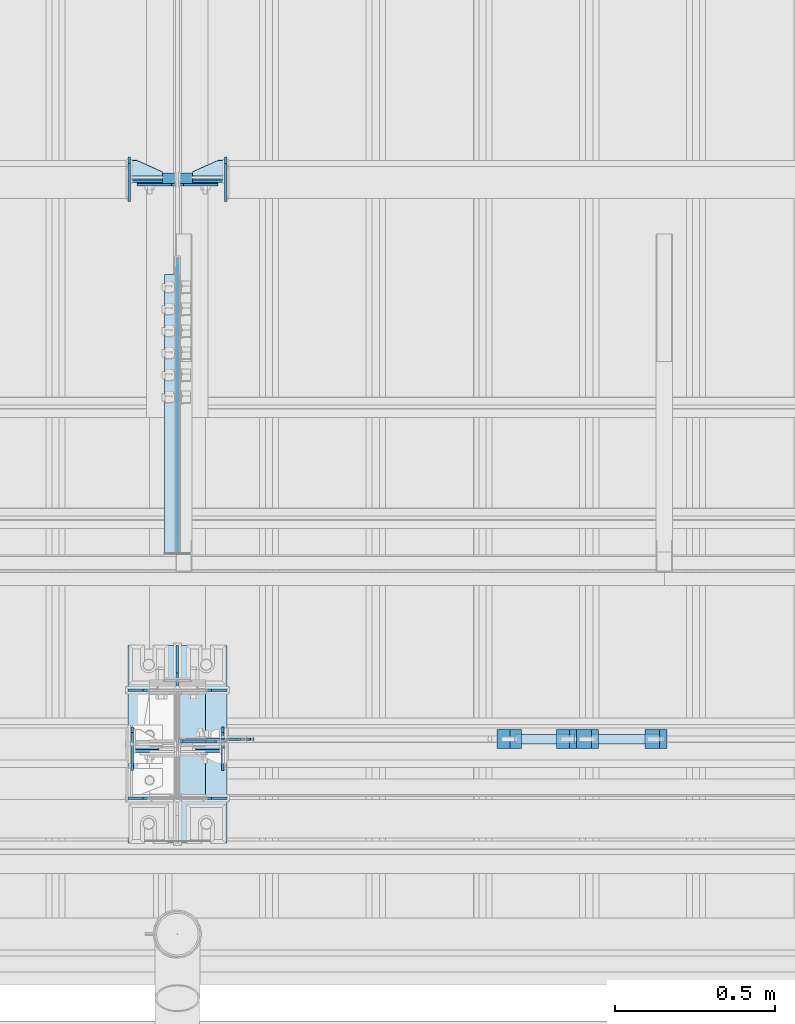
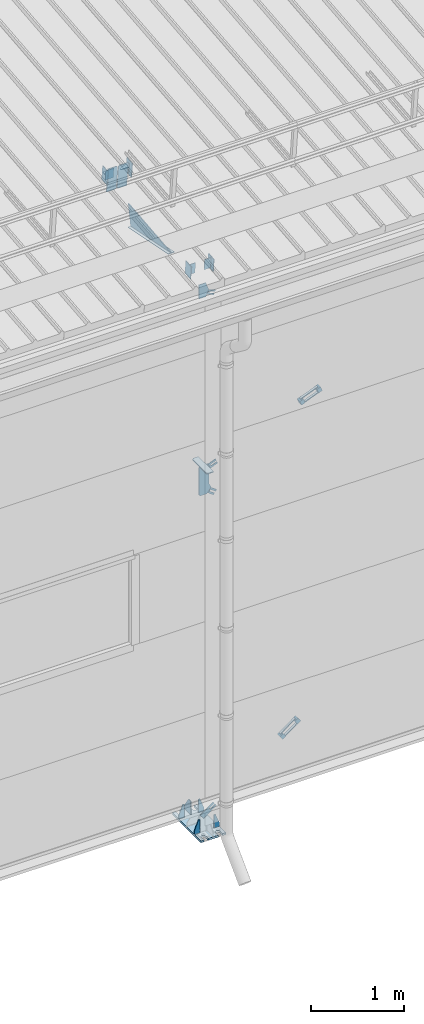
# One storey, part 123 of 709: 35 plates, 4 openings, 12 elements without a shape of their own.
"""IFC4 building model written with IfcOpenShell, lengths in millimetres."""

from ifc_helpers import new_model, si_unit, direction, frame, origin_with_axes, place, context, subcontext, project, spatial, line, arc, indexed_curve, outline, extrude, material, element, aggregate, save


model = new_model("IFC4")

# Units and contexts
model_context = context("Model", 3, precision=0.2, world=origin_with_axes(), true_north=direction((0.0, 1.0)))
body_context = subcontext(model_context, "Body", "Model", "MODEL_VIEW")
ifc_project = project(units=[si_unit("LENGTHUNIT", "METRE", prefix="MILLI"), si_unit("AREAUNIT", "SQUARE_METRE"), si_unit("VOLUMEUNIT", "CUBIC_METRE"), si_unit("MASSUNIT", "GRAM", prefix="KILO"), si_unit("TIMEUNIT", "SECOND"), si_unit("PLANEANGLEUNIT", "RADIAN"), si_unit("SOLIDANGLEUNIT", "STERADIAN"), si_unit("THERMODYNAMICTEMPERATUREUNIT", "DEGREE_CELSIUS"), si_unit("LUMINOUSINTENSITYUNIT", "LUMEN")], contexts=[model_context])

# Site, building, storey
site_placement = place(None, origin_with_axes())
site = spatial("IfcSite", under=ifc_project, at=site_placement, CompositionType="ELEMENT")
building_placement = place(site_placement, origin_with_axes())
building = spatial("IfcBuilding", under=site, at=building_placement, Name="Undefined", CompositionType="ELEMENT")
storey_placement = place(building_placement, origin_with_axes())
storey = spatial("IfcBuildingStorey", under=building, at=storey_placement, Name="Undefined", CompositionType="ELEMENT", Elevation=0.0)

# Assembly, plates
assembly_1_placement = place(storey_placement, frame((22000.0, 346.0, 7089.70002), z_axis=(1.0, 0.0, 0.0), x_axis=(0.0, 0.9950371902, 0.099503719)))
assembly_1 = element("IfcElementAssembly", 1, at=assembly_1_placement, inside=storey)
ifc_material_1 = material(Name="C355-6", Category="STEEL")
plate_1_placement = place(assembly_1_placement, frame((1597.88359, 163.0, 127.0), z_axis=(-1.0, 0.0, 0.0), x_axis=(0.0, 0.0, -1.0)))
plate_1 = element("IfcPlate", 2, at=plate_1_placement, material=ifc_material_1, ObjectType="585", context=body_context, shape_type="SolidModel", body=[
    extrude(outline(indexed_curve([(0.0, 0.0), (108.0, 0.0), (123.0, 15.0), (123.0, 311.0), (108.0, 326.0), (0.0, 326.0)], segments=[line(1, 2, 3, 4, 5, 6, 1)])), frame((0.0, 0.0, 4.0), z_axis=(0.0, 0.0, 1.0), x_axis=(1.0, 0.0, 0.0)), (0.0, 0.0, -1.0), 8.0),
])
plate_2_placement = place(assembly_1_placement, frame((1597.88359, 163.0, -127.0), z_axis=(1.0, 0.0, 0.0), x_axis=(0.0, 0.0, 1.0)))
plate_2 = element("IfcPlate", 3, at=plate_2_placement, material=ifc_material_1, ObjectType="585", context=body_context, shape_type="SolidModel", body=[
    extrude(outline(indexed_curve([(0.0, 0.0), (108.0, 0.0), (123.0, 15.0), (123.0, 311.0), (108.0, 326.0), (0.0, 326.0)], segments=[line(1, 2, 3, 4, 5, 6, 1)])), frame((0.0, 0.0, 4.0), z_axis=(0.0, 0.0, 1.0), x_axis=(1.0, 0.0, 0.0)), (0.0, 0.0, -1.0), 8.0),
])
plate_3_placement = place(assembly_1_placement, frame((1336.51563, -171.28713, 0.0), z_axis=(0.0, 0.0, 1.0), x_axis=(-1.0, 0.0, 0.0)))
plate_3 = element("IfcPlate", 4, at=plate_3_placement, material=ifc_material_1, ObjectType="449", context=body_context, shape_type="SolidModel", body=[
    extrude(outline(indexed_curve([(0.0, 0.0), (928.3198, 0.0), (79.53997, 259.83056)], segments=[line(1, 2, 3, 1)])), frame((0.0, 0.0, 6.0), z_axis=(0.0, 0.0, 1.0), x_axis=(1.0, 0.0, 0.0)), (0.0, 0.0, -1.0), 12.0),
])
plate_4_placement = place(assembly_1_placement, frame((1255.8048, -434.94249, -40.0), z_axis=(0.2927142719, 0.9561999556, 0.0), x_axis=(-0.9561999556, 0.2927142719, 0.0)))
plate_4 = element("IfcPlate", 5, at=plate_4_placement, material=ifc_material_1, ObjectType="450", context=body_context, shape_type="SolidModel", body=[
    extrude(outline(indexed_curve([(0.0, 0.0), (887.65935, 0.0), (887.65935, 80.0), (0.0, 80.0)], segments=[line(1, 2, 3, 4, 1)])), frame((0.0, 0.0, 4.0), z_axis=(0.0, 0.0, 1.0), x_axis=(1.0, 0.0, 0.0)), (0.0, 0.0, -1.0), 8.0),
])
aggregate(assembly_1, [plate_1, plate_2, plate_3, plate_4])

# Assembly, plate
assembly_2_placement = place(storey_placement, frame((22000.0, 189.0, -155.0), z_axis=(0.0, -1.0, 0.0), x_axis=(0.8064830392, 0.0, 0.5912572262)))
assembly_2 = element("IfcElementAssembly", 6, at=assembly_2_placement, inside=storey)
plate_5_placement = place(assembly_2_placement, frame((254.17845, 11.0, 0.0), z_axis=(0.0, 0.0, -1.0), x_axis=(-1.0, 0.0, 0.0)))
plate_5 = element("IfcPlate", 7, at=plate_5_placement, material=ifc_material_1, ObjectType="490", context=body_context, shape_type="SolidModel", body=[
    extrude(outline(indexed_curve([(0.0, 0.0), (80.0, 0.0), (80.0, -22.0), (0.0, -22.0), (0.0, -46.0), (200.0, -46.0), (200.0, 24.0), (0.0, 24.0)], segments=[line(1, 2, 3, 4, 5, 6, 7, 8, 1)])), frame((0.0, 0.0, 4.0), z_axis=(0.0, 0.0, 1.0), x_axis=(1.0, 0.0, 0.0)), (0.0, 0.0, -1.0), 8.0),
])
aggregate(assembly_2, [plate_5])

# Assembly, plates
assembly_3_placement = place(storey_placement, frame((23204.08409, 159.0, 764.94919), z_axis=(-0.8064830392, 0.0, -0.5912572261), x_axis=(0.0, 1.0, 0.0)))
assembly_3 = element("IfcElementAssembly", 8, at=assembly_3_placement, inside=storey)
ifc_material_2 = material(Name="Steel_Undefined", Category="STEEL")
plate_6_placement = place(assembly_3_placement, frame((0.0, 0.0, 230.0), z_axis=(0.0, 0.0, 1.0), x_axis=(1.0, 0.0, 0.0)))
plate_6 = element("IfcPlate", 9, at=plate_6_placement, material=ifc_material_2, ObjectType="483", context=body_context, shape_type="SolidModel", body=[
    extrude(outline(indexed_curve([(0.0, 0.0), (60.0, 0.0), (60.0, 60.0), (0.0, 60.0)], segments=[line(1, 2, 3, 4, 1)])), frame((0.0, 0.0, 25.0), z_axis=(0.0, 0.0, 1.0), x_axis=(1.0, 0.0, 0.0)), (0.0, 0.0, -1.0), 50.0),
])
plate_7_placement = place(assembly_3_placement, frame((15.0, -6.0, 230.0), z_axis=(0.0, 1.0, 0.0), x_axis=(1.0, 0.0, 0.0)))
plate_7 = element("IfcPlate", 10, at=plate_7_placement, material=ifc_material_2, ObjectType="484", context=body_context, shape_type="SolidModel", body=[
    extrude(outline(indexed_curve([(0.0, 0.0), (30.0, 0.0), (30.0, 230.0), (0.0, 230.0)], segments=[line(1, 2, 3, 4, 1)])), frame((0.0, 0.0, 6.0), z_axis=(0.0, 0.0, 1.0), x_axis=(1.0, 0.0, 0.0)), (0.0, 0.0, -1.0), 12.0),
])
plate_8_placement = place(assembly_3_placement, frame((15.0, 66.0, 230.0), z_axis=(0.0, 1.0, 0.0), x_axis=(1.0, 0.0, 0.0)))
plate_8 = element("IfcPlate", 11, at=plate_8_placement, material=ifc_material_2, ObjectType="484", context=body_context, shape_type="SolidModel", body=[
    extrude(outline(indexed_curve([(0.0, 0.0), (30.0, 0.0), (30.0, 230.0), (0.0, 230.0)], segments=[line(1, 2, 3, 4, 1)])), frame((0.0, 0.0, 6.0), z_axis=(0.0, 0.0, 1.0), x_axis=(1.0, 0.0, 0.0)), (0.0, 0.0, -1.0), 12.0),
])
plate_9_placement = place(assembly_3_placement, origin_with_axes())
plate_9 = element("IfcPlate", 12, at=plate_9_placement, material=ifc_material_2, ObjectType="482", context=body_context, shape_type="SolidModel", body=[
    extrude(outline(indexed_curve([(0.0, 0.0), (60.0, 0.0), (60.0, 60.0), (0.0, 60.0)], segments=[line(1, 2, 3, 4, 1)])), frame((0.0, 0.0, 25.0), z_axis=(0.0, 0.0, 1.0), x_axis=(1.0, 0.0, 0.0)), (0.0, 0.0, -1.0), 50.0),
])
aggregate(assembly_3, [plate_6, plate_7, plate_8, plate_9])

# Assembly, plate
assembly_4_placement = place(storey_placement, frame((22087.0, 189.0, 4180.0), z_axis=(0.0, -1.0, 0.0), x_axis=(0.8064830392, 0.0, -0.5912572261)))
assembly_4 = element("IfcElementAssembly", 13, at=assembly_4_placement, inside=storey)
plate_10_placement = place(assembly_4_placement, frame((150.0, -35.0, 0.0), z_axis=(0.0, 0.0, -1.0), x_axis=(-1.0, 0.0, 0.0)))
plate_10 = element("IfcPlate", 14, at=plate_10_placement, material=ifc_material_1, ObjectType="525", context=body_context, shape_type="SolidModel", body=[
    extrude(outline(indexed_curve([(0.0, 0.0), (200.0, 0.0), (200.0, 70.0), (0.0, 70.0), (0.0, 46.0), (80.0, 46.0), (80.0, 24.0), (0.0, 24.0)], segments=[line(1, 2, 3, 4, 5, 6, 7, 8, 1)])), frame((0.0, 0.0, 4.0), z_axis=(0.0, 0.0, 1.0), x_axis=(1.0, 0.0, 0.0)), (0.0, 0.0, -1.0), 8.0),
])
aggregate(assembly_4, [plate_10])

assembly_5_placement = place(storey_placement, frame((22087.0, 189.0, 4440.0), z_axis=(0.0, -1.0, 0.0), x_axis=(0.9286065, 0.0, 0.371065989)))
assembly_5 = element("IfcElementAssembly", 15, at=assembly_5_placement, inside=storey)
plate_11_placement = place(assembly_5_placement, frame((150.0, -35.0, 0.0), z_axis=(0.0, 0.0, -1.0), x_axis=(-1.0, 0.0, 0.0)))
plate_11 = element("IfcPlate", 16, at=plate_11_placement, material=ifc_material_1, ObjectType="525", context=body_context, shape_type="SolidModel", body=[
    extrude(outline(indexed_curve([(0.0, 0.0), (200.0, 0.0), (200.0, 70.0), (0.0, 70.0), (0.0, 46.0), (80.0, 46.0), (80.0, 24.0), (0.0, 24.0)], segments=[line(1, 2, 3, 4, 5, 6, 7, 8, 1)])), frame((0.0, 0.0, 4.0), z_axis=(0.0, 0.0, 1.0), x_axis=(1.0, 0.0, 0.0)), (0.0, 0.0, -1.0), 8.0),
])
aggregate(assembly_5, [plate_11])

# Assembly, plates
assembly_6_placement = place(storey_placement, frame((23482.70687, 159.0, 5030.02317), z_axis=(-0.9286065, 0.0, -0.371065989), x_axis=(0.0, 1.0, 0.0)))
assembly_6 = element("IfcElementAssembly", 17, at=assembly_6_placement, inside=storey)
plate_12_placement = place(assembly_6_placement, frame((0.0, 0.0, 230.0), z_axis=(0.0, 0.0, 1.0), x_axis=(1.0, 0.0, 0.0)))
plate_12 = element("IfcPlate", 18, at=plate_12_placement, material=ifc_material_2, ObjectType="483", context=body_context, shape_type="SolidModel", body=[
    extrude(outline(indexed_curve([(0.0, 0.0), (60.0, 0.0), (60.0, 60.0), (0.0, 60.0)], segments=[line(1, 2, 3, 4, 1)])), frame((0.0, 0.0, 25.0), z_axis=(0.0, 0.0, 1.0), x_axis=(1.0, 0.0, 0.0)), (0.0, 0.0, -1.0), 50.0),
])
plate_13_placement = place(assembly_6_placement, frame((15.0, -6.0, 230.0), z_axis=(0.0, 1.0, 0.0), x_axis=(1.0, 0.0, 0.0)))
plate_13 = element("IfcPlate", 19, at=plate_13_placement, material=ifc_material_2, ObjectType="484", context=body_context, shape_type="SolidModel", body=[
    extrude(outline(indexed_curve([(0.0, 0.0), (30.0, 0.0), (30.0, 230.0), (0.0, 230.0)], segments=[line(1, 2, 3, 4, 1)])), frame((0.0, 0.0, 6.0), z_axis=(0.0, 0.0, 1.0), x_axis=(1.0, 0.0, 0.0)), (0.0, 0.0, -1.0), 12.0),
])
plate_14_placement = place(assembly_6_placement, frame((15.0, 66.0, 230.0), z_axis=(0.0, 1.0, 0.0), x_axis=(1.0, 0.0, 0.0)))
plate_14 = element("IfcPlate", 20, at=plate_14_placement, material=ifc_material_2, ObjectType="484", context=body_context, shape_type="SolidModel", body=[
    extrude(outline(indexed_curve([(0.0, 0.0), (30.0, 0.0), (30.0, 230.0), (0.0, 230.0)], segments=[line(1, 2, 3, 4, 1)])), frame((0.0, 0.0, 6.0), z_axis=(0.0, 0.0, 1.0), x_axis=(1.0, 0.0, 0.0)), (0.0, 0.0, -1.0), 12.0),
])
plate_15_placement = place(assembly_6_placement, origin_with_axes())
plate_15 = element("IfcPlate", 21, at=plate_15_placement, material=ifc_material_2, ObjectType="482", context=body_context, shape_type="SolidModel", body=[
    extrude(outline(indexed_curve([(0.0, 0.0), (60.0, 0.0), (60.0, 60.0), (0.0, 60.0)], segments=[line(1, 2, 3, 4, 1)])), frame((0.0, 0.0, 25.0), z_axis=(0.0, 0.0, 1.0), x_axis=(1.0, 0.0, 0.0)), (0.0, 0.0, -1.0), 50.0),
])
aggregate(assembly_6, [plate_12, plate_13, plate_14, plate_15])

# Assembly, plate
assembly_7_placement = place(storey_placement, frame((22087.0, 189.0, 6768.03718), z_axis=(0.0, -1.0, 0.0), x_axis=(0.9286065, 0.0, -0.371065989)))
assembly_7 = element("IfcElementAssembly", 22, at=assembly_7_placement, inside=storey)
plate_16_placement = place(assembly_7_placement, frame((123.06736, -11.0, 0.0), z_axis=(0.0, 0.0, 1.0), x_axis=(-1.0, 0.0, 0.0)))
plate_16 = element("IfcPlate", 23, at=plate_16_placement, material=ifc_material_1, ObjectType="556", context=body_context, shape_type="SolidModel", body=[
    extrude(outline(indexed_curve([(0.0, 0.0), (80.0, 0.0), (80.0, -22.0), (0.0, -22.0), (0.0, -41.0), (180.0, -41.0), (180.0, 19.0), (0.0, 19.0)], segments=[line(1, 2, 3, 4, 5, 6, 7, 8, 1)])), frame((0.0, 0.0, 4.0), z_axis=(0.0, 0.0, 1.0), x_axis=(1.0, 0.0, 0.0)), (0.0, 0.0, -1.0), 8.0),
])
aggregate(assembly_7, [plate_16])

# Assembly, plates, voiding features
assembly_8_placement = place(storey_placement, frame((22000.0, 173.0, -200.0), z_axis=(-1.0, 0.0, 0.0), x_axis=(0.0, 0.0, 1.0)))
assembly_8 = element("IfcElementAssembly", 24, at=assembly_8_placement, inside=storey)
plate_17_placement = place(assembly_8_placement, frame((6931.61775, 8.00694, -97.28783), z_axis=(-5.5187e-06, -0.9999998141, 0.0006097898), x_axis=(0.9286064751, -0.000231397, -0.3710659791)))
plate_17 = element("IfcPlate", 25, at=plate_17_placement, material=ifc_material_1, Name="PLATE", ObjectType="555", context=body_context, shape_type="SolidModel", body=[
    extrude(outline(indexed_curve([(0.0, 0.0), (70.0, 0.0), (146.9134, 69.78458), (115.74386, 147.78751), (-55.02687, 79.54846), (-23.23974, 0.0)], segments=[line(1, 2, 3, 4, 5, 6, 1)])), frame((0.0, 0.0, 4.0), z_axis=(0.0, 0.0, 1.0), x_axis=(1.0, 0.0, 0.0)), (0.0, 0.0, -1.0), 8.0),
])
plate_18_placement = place(assembly_8_placement, frame((4700.34059, 10.0, -116.73236), z_axis=(0.0, 1.0, 0.0), x_axis=(-0.9286065, 0.0, -0.371065989)))
plate_18 = element("IfcPlate", 26, at=plate_18_placement, material=ifc_material_1, ObjectType="552", context=body_context, shape_type="SolidModel", body=[
    extrude(outline(indexed_curve([(0.0, 0.0), (90.0, 0.0), (115.55903, 35.1197), (245.56394, 87.06894), (305.02493, 81.82799), (352.68082, 158.17533), (321.98714, 234.98741), (302.49206, 243.35051), (-28.27311, 111.17859), (-36.63622, 91.68351)], segments=[line(1, 2, 3, 4, 5, 6, 7, 8, 9, 10, 1)])), frame((0.0, 0.0, 6.0), z_axis=(0.0, 0.0, 1.0), x_axis=(1.0, 0.0, 0.0)), (0.0, 0.0, -1.0), 12.0),
])
plate_19_placement = place(assembly_8_placement, frame((25.0, 173.0, 0.0), z_axis=(0.0, 0.0, -1.0), x_axis=(0.0, 1.0, 0.0)))
plate_19 = element("IfcPlate", 27, at=plate_19_placement, material=ifc_material_1, ObjectType="418", context=body_context, shape_type="SolidModel", body=[
    extrude(outline(indexed_curve([(0.0, 0.0), (135.0, 0.0), (135.0, 50.0), (50.0, 175.0), (0.0, 175.0)], segments=[line(1, 2, 3, 4, 5, 1)])), frame((0.0, 0.0, 4.0), z_axis=(0.0, 0.0, 1.0), x_axis=(1.0, 0.0, 0.0)), (0.0, 0.0, -1.0), 8.0),
])
plate_20_placement = place(assembly_8_placement, frame((25.0, 168.5, 87.0), z_axis=(0.0, 1.0, 0.0), x_axis=(0.0, 0.0, 1.0)))
plate_20 = element("IfcPlate", 28, at=plate_20_placement, material=ifc_material_1, ObjectType="419", context=body_context, shape_type="SolidModel", body=[
    extrude(outline(indexed_curve([(0.0, 0.0), (68.0, 0.0), (68.0, 50.0), (20.0, 175.0), (0.0, 175.0)], segments=[line(1, 2, 3, 4, 5, 1)])), frame((0.0, 0.0, 4.0), z_axis=(0.0, 0.0, 1.0), x_axis=(1.0, 0.0, 0.0)), (0.0, 0.0, -1.0), 8.0),
])
plate_21_placement = place(assembly_8_placement, frame((25.0, -168.5, 87.0), z_axis=(0.0, 1.0, 0.0), x_axis=(0.0, 0.0, 1.0)))
plate_21 = element("IfcPlate", 29, at=plate_21_placement, material=ifc_material_1, ObjectType="419", context=body_context, shape_type="SolidModel", body=[
    extrude(outline(indexed_curve([(0.0, 0.0), (68.0, 0.0), (68.0, 50.0), (20.0, 175.0), (0.0, 175.0)], segments=[line(1, 2, 3, 4, 5, 1)])), frame((0.0, 0.0, 4.0), z_axis=(0.0, 0.0, 1.0), x_axis=(1.0, 0.0, 0.0)), (0.0, 0.0, -1.0), 8.0),
])
plate_22_placement = place(assembly_8_placement, frame((25.0, 168.5, -87.0), z_axis=(0.0, -1.0, 0.0), x_axis=(0.0, 0.0, -1.0)))
plate_22 = element("IfcPlate", 30, at=plate_22_placement, material=ifc_material_1, ObjectType="419", context=body_context, shape_type="SolidModel", body=[
    extrude(outline(indexed_curve([(0.0, 0.0), (68.0, 0.0), (68.0, 50.0), (20.0, 175.0), (0.0, 175.0)], segments=[line(1, 2, 3, 4, 5, 1)])), frame((0.0, 0.0, 4.0), z_axis=(0.0, 0.0, 1.0), x_axis=(1.0, 0.0, 0.0)), (0.0, 0.0, -1.0), 8.0),
])
plate_23_placement = place(assembly_8_placement, frame((25.0, -168.5, -87.0), z_axis=(0.0, -1.0, 0.0), x_axis=(0.0, 0.0, -1.0)))
plate_23 = element("IfcPlate", 31, at=plate_23_placement, material=ifc_material_1, ObjectType="419", context=body_context, shape_type="SolidModel", body=[
    extrude(outline(indexed_curve([(0.0, 0.0), (68.0, 0.0), (68.0, 50.0), (20.0, 175.0), (0.0, 175.0)], segments=[line(1, 2, 3, 4, 5, 1)])), frame((0.0, 0.0, 4.0), z_axis=(0.0, 0.0, 1.0), x_axis=(1.0, 0.0, 0.0)), (0.0, 0.0, -1.0), 8.0),
])
plate_24_placement = place(assembly_8_placement, frame((12.5, -308.0, 155.0), z_axis=(1.0, 0.0, 0.0), x_axis=(0.0, 0.0, -1.0)))
plate_24 = element("IfcPlate", 32, at=plate_24_placement, material=ifc_material_1, context=body_context, shape_type="SolidModel", body=[
    extrude(outline(indexed_curve([(0.0, 0.0), (310.0, 0.0), (310.0, 616.0), (0.0, 616.0)], segments=[line(1, 2, 3, 4, 1)])), frame((0.0, 0.0, 12.5), z_axis=(0.0, 0.0, 1.0), x_axis=(1.0, 0.0, 0.0)), (0.0, 0.0, -1.0), 25.0),
])
voiding_feature_1_placement = place(plate_24_placement, frame((40.0, 616.0, 0.0), z_axis=(0.0, 0.0, -1.0), x_axis=(1.0, 0.0, 0.0)))
element("IfcVoidingFeature", 33, at=voiding_feature_1_placement, cuts=plate_24, PredefinedType="HOLE", context=body_context, shape_type="SolidModel", body=[
    extrude(outline(indexed_curve([(0.0, 0.0), (50.0, 0.0), (50.0, 60.0), (42.67767, 77.67767), (25.0, 85.0), (25.0, 85.0), (7.32233, 77.67767), (0.0, 60.0)], segments=[line(1, 2, 3), arc(3, 4, 5), line(5, 6), arc(6, 7, 8), line(8, 1)])), frame((0.0, 0.0, 12.5), z_axis=(0.0, 0.0, 1.0), x_axis=(1.0, 0.0, 0.0)), (0.0, 0.0, -1.0), 25.0),
])
voiding_feature_2_placement = place(plate_24_placement, frame((40.0, 0.0, 0.0), z_axis=(0.0, 0.0, 1.0), x_axis=(1.0, 0.0, 0.0)))
element("IfcVoidingFeature", 34, at=voiding_feature_2_placement, cuts=plate_24, PredefinedType="HOLE", context=body_context, shape_type="SolidModel", body=[
    extrude(outline(indexed_curve([(0.0, 0.0), (50.0, 0.0), (50.0, 60.0), (42.67767, 77.67767), (25.0, 85.0), (25.0, 85.0), (7.32233, 77.67767), (0.0, 60.0)], segments=[line(1, 2, 3), arc(3, 4, 5), line(5, 6), arc(6, 7, 8), line(8, 1)])), frame((0.0, 0.0, 12.5), z_axis=(0.0, 0.0, 1.0), x_axis=(1.0, 0.0, 0.0)), (0.0, 0.0, -1.0), 25.0),
])
voiding_feature_3_placement = place(plate_24_placement, frame((270.0, 616.0, 0.0), z_axis=(0.0, 0.0, 1.0), x_axis=(-1.0, 0.0, 0.0)))
element("IfcVoidingFeature", 35, at=voiding_feature_3_placement, cuts=plate_24, PredefinedType="HOLE", context=body_context, shape_type="SolidModel", body=[
    extrude(outline(indexed_curve([(0.0, 0.0), (50.0, 0.0), (50.0, 60.0), (42.67767, 77.67767), (25.0, 85.0), (25.0, 85.0), (7.32233, 77.67767), (0.0, 60.0)], segments=[line(1, 2, 3), arc(3, 4, 5), line(5, 6), arc(6, 7, 8), line(8, 1)])), frame((0.0, 0.0, 12.5), z_axis=(0.0, 0.0, 1.0), x_axis=(1.0, 0.0, 0.0)), (0.0, 0.0, -1.0), 25.0),
])
voiding_feature_4_placement = place(plate_24_placement, frame((270.0, 0.0, 0.0), z_axis=(0.0, 0.0, -1.0), x_axis=(-1.0, 0.0, 0.0)))
element("IfcVoidingFeature", 36, at=voiding_feature_4_placement, cuts=plate_24, PredefinedType="HOLE", context=body_context, shape_type="SolidModel", body=[
    extrude(outline(indexed_curve([(0.0, 0.0), (50.0, 0.0), (50.0, 60.0), (42.67767, 77.67767), (25.0, 85.0), (25.0, 85.0), (7.32233, 77.67767), (0.0, 60.0)], segments=[line(1, 2, 3), arc(3, 4, 5), line(5, 6), arc(6, 7, 8), line(8, 1)])), frame((0.0, 0.0, 12.5), z_axis=(0.0, 0.0, 1.0), x_axis=(1.0, 0.0, 0.0)), (0.0, 0.0, -1.0), 25.0),
])
plate_25_placement = place(assembly_8_placement, frame((4706.34059, -163.0, -87.0), z_axis=(-1.0, 0.0, 0.0), x_axis=(0.0, 0.0, 1.0)))
plate_25 = element("IfcPlate", 37, at=plate_25_placement, material=ifc_material_1, ObjectType="553", context=body_context, shape_type="SolidModel", body=[
    extrude(outline(indexed_curve([(0.0, 0.0), (68.0, 0.0), (83.0, 15.0), (83.0, 311.0), (68.0, 326.0), (0.0, 326.0)], segments=[line(1, 2, 3, 4, 5, 6, 1)])), frame((0.0, 0.0, 6.0), z_axis=(0.0, 0.0, 1.0), x_axis=(1.0, 0.0, 0.0)), (0.0, 0.0, -1.0), 12.0),
])
aggregate(assembly_8, [plate_17, plate_18, plate_19, plate_20, plate_21, plate_22, plate_23, plate_24, plate_25])

# Assembly, plates
assembly_9_placement = place(storey_placement, frame((16000.0, 158.95533, 7154.40952), z_axis=(0.0, 0.9950371902, 0.099503719), x_axis=(1.0, 0.0, 0.0)))
assembly_9 = element("IfcElementAssembly", 38, at=assembly_9_placement, inside=storey)
plate_26_placement = place(assembly_9_placement, frame((5943.0, 72.0, 0.0), z_axis=(0.0, 0.0, 1.0), x_axis=(-1.0, 0.0, 0.0)))
plate_26 = element("IfcPlate", 39, at=plate_26_placement, material=ifc_material_1, ObjectType="597", context=body_context, shape_type="SolidModel", body=[
    extrude(outline(indexed_curve([(0.0, 0.0), (80.0, 0.0), (80.0, 144.0), (0.0, 144.0)], segments=[line(1, 2, 3, 4, 1)])), frame((0.0, 0.0, 4.0), z_axis=(0.0, 0.0, 1.0), x_axis=(1.0, 0.0, 0.0)), (0.0, 0.0, -1.0), 8.0),
])
plate_27_placement = place(assembly_9_placement, frame((5859.0, -87.0, 60.0), z_axis=(1.0, 0.0, 0.0), x_axis=(0.0, 0.0, -1.0)))
plate_27 = element("IfcPlate", 40, at=plate_27_placement, material=ifc_material_1, ObjectType="596", context=body_context, shape_type="SolidModel", body=[
    extrude(outline(indexed_curve([(0.0, 0.0), (120.0, 0.0), (120.0, 174.0), (0.0, 174.0)], segments=[line(1, 2, 3, 4, 1)])), frame((0.0, 0.0, 4.0), z_axis=(0.0, 0.0, 1.0), x_axis=(1.0, 0.0, 0.0)), (0.0, 0.0, -1.0), 8.0),
])
aggregate(assembly_9, [plate_26, plate_27])

assembly_10_placement = place(storey_placement, frame((16000.0, 1936.65012, 7322.12913), z_axis=(0.0, 0.9950371902, 0.099503719), x_axis=(1.0, 0.0, 0.0)))
assembly_10 = element("IfcElementAssembly", 41, at=assembly_10_placement, inside=storey)
plate_28_placement = place(assembly_10_placement, frame((5849.0, -98.0, 60.0), z_axis=(1.0, 0.0, 0.0), x_axis=(0.0, 0.0, -1.0)))
plate_28 = element("IfcPlate", 42, at=plate_28_placement, material=ifc_material_1, ObjectType="586", context=body_context, shape_type="SolidModel", body=[
    extrude(outline(indexed_curve([(0.0, 0.0), (120.0, 0.0), (120.0, 196.0), (0.0, 196.0)], segments=[line(1, 2, 3, 4, 1)])), frame((0.0, 0.0, 4.0), z_axis=(0.0, 0.0, 1.0), x_axis=(1.0, 0.0, 0.0)), (0.0, 0.0, -1.0), 8.0),
])
plate_29_placement = place(assembly_10_placement, frame((5953.0, 65.0, 0.0), z_axis=(0.0, 0.0, 1.0), x_axis=(-1.0, 0.0, 0.0)))
plate_29 = element("IfcPlate", 43, at=plate_29_placement, material=ifc_material_1, ObjectType="587", context=body_context, shape_type="SolidModel", body=[
    extrude(outline(indexed_curve([(0.0, 0.0), (100.0, 0.0), (100.0, 130.0), (0.0, 130.0)], segments=[line(1, 2, 3, 4, 1)])), frame((0.0, 0.0, 4.0), z_axis=(0.0, 0.0, 1.0), x_axis=(1.0, 0.0, 0.0)), (0.0, 0.0, -1.0), 8.0),
])
plate_30_placement = place(assembly_10_placement, frame((5953.0, 0.0, 60.0), z_axis=(0.0, -1.0, 0.0), x_axis=(-1.0, 0.0, 0.0)))
plate_30 = element("IfcPlate", 44, at=plate_30_placement, material=ifc_material_1, ObjectType="588", context=body_context, shape_type="SolidModel", body=[
    extrude(outline(indexed_curve([(0.0, 36.0), (80.0, 0.0), (100.0, 0.0), (100.0, 56.0), (0.0, 56.0)], segments=[line(1, 2, 3, 4, 5, 1)])), frame((0.0, 0.0, 4.0), z_axis=(0.0, 0.0, 1.0), x_axis=(1.0, 0.0, 0.0)), (0.0, 0.0, -1.0), 8.0),
])
aggregate(assembly_10, [plate_28, plate_29, plate_30])

assembly_11_placement = place(storey_placement, frame((22000.0, 158.95533, 7154.40952), z_axis=(0.0, 0.9950371902, 0.099503719), x_axis=(1.0, 0.0, 0.0)))
assembly_11 = element("IfcElementAssembly", 45, at=assembly_11_placement, inside=storey)
plate_31_placement = place(assembly_11_placement, frame((141.0, -87.0, -60.0), z_axis=(-1.0, 0.0, 0.0), x_axis=(0.0, 0.0, 1.0)))
plate_31 = element("IfcPlate", 46, at=plate_31_placement, material=ifc_material_1, ObjectType="596", context=body_context, shape_type="SolidModel", body=[
    extrude(outline(indexed_curve([(0.0, 0.0), (120.0, 0.0), (120.0, 174.0), (0.0, 174.0)], segments=[line(1, 2, 3, 4, 1)])), frame((0.0, 0.0, 4.0), z_axis=(0.0, 0.0, 1.0), x_axis=(1.0, 0.0, 0.0)), (0.0, 0.0, -1.0), 8.0),
])
plate_32_placement = place(assembly_11_placement, frame((57.0, -72.0, 0.0), z_axis=(0.0, 0.0, 1.0), x_axis=(1.0, 0.0, 0.0)))
plate_32 = element("IfcPlate", 47, at=plate_32_placement, material=ifc_material_1, ObjectType="597", context=body_context, shape_type="SolidModel", body=[
    extrude(outline(indexed_curve([(0.0, 0.0), (80.0, 0.0), (80.0, 144.0), (0.0, 144.0)], segments=[line(1, 2, 3, 4, 1)])), frame((0.0, 0.0, 4.0), z_axis=(0.0, 0.0, 1.0), x_axis=(1.0, 0.0, 0.0)), (0.0, 0.0, -1.0), 8.0),
])
aggregate(assembly_11, [plate_31, plate_32])

assembly_12_placement = place(storey_placement, frame((22000.0, 1936.65012, 7322.12913), z_axis=(0.0, 0.9950371902, 0.099503719), x_axis=(1.0, 0.0, 0.0)))
assembly_12 = element("IfcElementAssembly", 48, at=assembly_12_placement, inside=storey)
plate_33_placement = place(assembly_12_placement, frame((47.0, 0.0, 60.0), z_axis=(0.0, 1.0, 0.0), x_axis=(1.0, 0.0, 0.0)))
plate_33 = element("IfcPlate", 49, at=plate_33_placement, material=ifc_material_1, ObjectType="588", context=body_context, shape_type="SolidModel", body=[
    extrude(outline(indexed_curve([(0.0, 36.0), (80.0, 0.0), (100.0, 0.0), (100.0, 56.0), (0.0, 56.0)], segments=[line(1, 2, 3, 4, 5, 1)])), frame((0.0, 0.0, 4.0), z_axis=(0.0, 0.0, 1.0), x_axis=(1.0, 0.0, 0.0)), (0.0, 0.0, -1.0), 8.0),
])
plate_34_placement = place(assembly_12_placement, frame((47.0, -65.0, 0.0), z_axis=(0.0, 0.0, 1.0), x_axis=(1.0, 0.0, 0.0)))
plate_34 = element("IfcPlate", 50, at=plate_34_placement, material=ifc_material_1, ObjectType="587", context=body_context, shape_type="SolidModel", body=[
    extrude(outline(indexed_curve([(0.0, 0.0), (100.0, 0.0), (100.0, 130.0), (0.0, 130.0)], segments=[line(1, 2, 3, 4, 1)])), frame((0.0, 0.0, 4.0), z_axis=(0.0, 0.0, 1.0), x_axis=(1.0, 0.0, 0.0)), (0.0, 0.0, -1.0), 8.0),
])
plate_35_placement = place(assembly_12_placement, frame((151.0, -98.0, -60.0), z_axis=(-1.0, 0.0, 0.0), x_axis=(0.0, 0.0, 1.0)))
plate_35 = element("IfcPlate", 51, at=plate_35_placement, material=ifc_material_1, ObjectType="586", context=body_context, shape_type="SolidModel", body=[
    extrude(outline(indexed_curve([(0.0, 0.0), (120.0, 0.0), (120.0, 196.0), (0.0, 196.0)], segments=[line(1, 2, 3, 4, 1)])), frame((0.0, 0.0, 4.0), z_axis=(0.0, 0.0, 1.0), x_axis=(1.0, 0.0, 0.0)), (0.0, 0.0, -1.0), 8.0),
])
aggregate(assembly_12, [plate_33, plate_34, plate_35])

save(model, "model.ifc")
